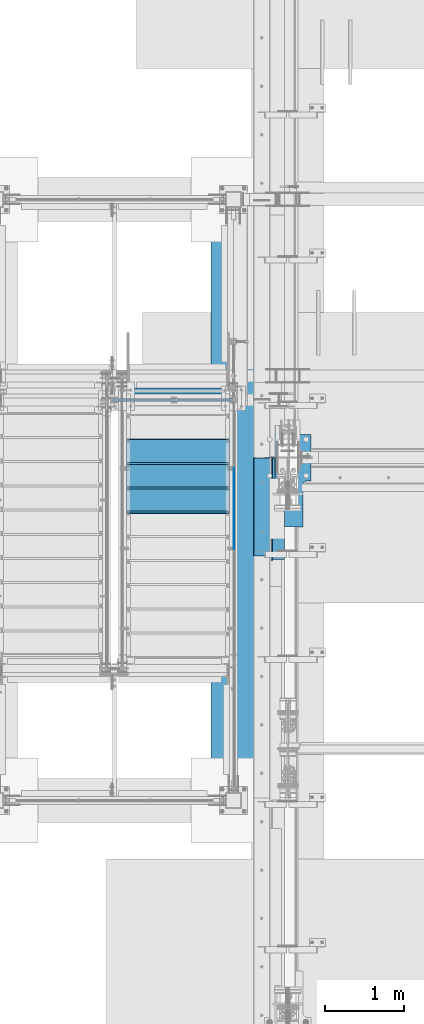
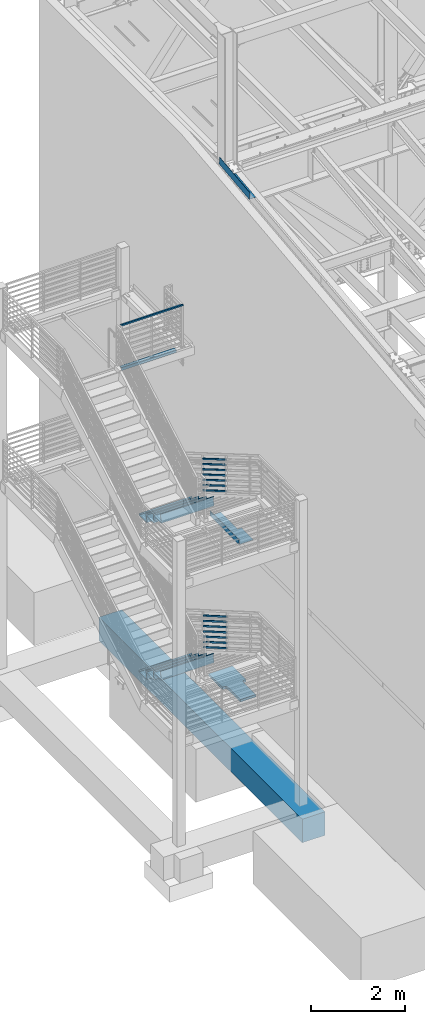
# One storey, part 762 of 1179: 14 members, 12 beams, 10 elements without a shape of their own.
"""IFC2X3 building model written with IfcOpenShell, lengths in millimetres."""

from ifc_helpers import new_model, si_unit, frame, origin_with_axes, place, context, subcontext, project, spatial, faceted_brep, material, type_object, element, aggregate, save


model = new_model("IFC2X3")

# Units and contexts
model_context = context("Model", 3, precision=1e-05, world=origin_with_axes())
body_context = subcontext(model_context, "Body", "Model", "MODEL_VIEW")
ifc_project = project(units=[si_unit("LENGTHUNIT", "METRE", prefix="MILLI"), si_unit("AREAUNIT", "SQUARE_METRE"), si_unit("VOLUMEUNIT", "CUBIC_METRE"), si_unit("MASSUNIT", "GRAM", prefix="KILO"), si_unit("TIMEUNIT", "SECOND"), si_unit("PLANEANGLEUNIT", "RADIAN"), si_unit("SOLIDANGLEUNIT", "STERADIAN"), si_unit("THERMODYNAMICTEMPERATUREUNIT", "DEGREE_CELSIUS"), si_unit("LUMINOUSINTENSITYUNIT", "LUMEN")], contexts=[model_context])

# Site, building, storey
site_placement = place(None, origin_with_axes())
site = spatial("IfcSite", under=ifc_project, at=site_placement, CompositionType="ELEMENT")
building_placement = place(site_placement, origin_with_axes())
building = spatial("IfcBuilding", under=site, at=building_placement, Name="Undefined", CompositionType="ELEMENT")
storey_placement = place(building_placement, origin_with_axes())
storey = spatial("IfcBuildingStorey", under=building, at=storey_placement, Name="Undefined", CompositionType="ELEMENT", Elevation=0.0)

# Assembly, beam
assembly_1_placement = place(storey_placement, origin_with_axes())
assembly_1 = element("IfcElementAssembly", 1, at=assembly_1_placement, inside=storey, Name="GUARDRAIL", AssemblyPlace="NOTDEFINED", PredefinedType="RIGID_FRAME")
ifc_material_1 = material()
beam_type_1 = type_object("IfcBeamType", Name="HSS1-1/2X1-1/2X1/4", PredefinedType="NOTDEFINED")
beam_1_placement = place(assembly_1_placement, frame((-1752.5993037225, 35115.5, 9213.90291797146), z_axis=(3.65500000116299e-05, 0.0, 0.999999999332049), x_axis=(0.999999999332049, 0.0, -3.65500000117319e-05)))
beam_1 = element("IfcBeam", 2, at=beam_1_placement, type_object=beam_type_1, material=ifc_material_1, Name="GUARDRAIL", ObjectType="HSS1-1/2X1-1/2X1/4", context=body_context, shape_type="Brep", body=[
    faceted_brep([(12.6997672797793, 12.6999993299978, -12.6999993300051), (12.6997672797793, -12.6999993299978, -12.6999993300051), (1511.30115616268, -12.6999993299978, -12.6999993299942), (1485.90022919769, 12.6999993299978, -12.699999329996), (-12.7011597941691, -12.6999993299978, 12.6999993300033), (1511.30115618808, -12.6999993299978, 12.699999330016), (-12.7011597941691, 12.6999993299978, 12.6999993300033), (1485.90022922309, 12.6999993299978, 12.6999993300142), (19.0499999999993, 19.0499992349996, -19.0499992350015), (-19.0513918026652, 19.0499992350015, 19.0499992350051), (1479.54999724818, 19.0499992350015, 19.049999235016), (1479.54999721008, 19.0499992350015, -19.0499992349978), (-19.0513918026652, -19.0499992350015, 19.0499992350051), (1517.65138817569, -19.0499992350015, 19.0499992350178), (19.0499999999993, -19.0499992349996, -19.0499992350015), (1517.65138813759, -19.0499992350015, -19.049999234996)], [[[0, 1, 2, 3]], [[1, 4, 5, 2]], [[4, 6, 7, 5]], [[6, 0, 3, 7]], [[8, 9, 10, 11]], [[9, 12, 13, 10]], [[12, 14, 15, 13]], [[14, 8, 11, 15]], [[13, 15, 11, 10], [5, 7, 3, 2]], [[14, 12, 9, 8], [6, 4, 1, 0]]]),
])
aggregate(assembly_1, [beam_1])

assembly_2_placement = place(storey_placement, origin_with_axes())
assembly_2 = element("IfcElementAssembly", 3, at=assembly_2_placement, inside=storey, Name="BEAM", AssemblyPlace="NOTDEFINED", PredefinedType="RIGID_FRAME")
ifc_material_2 = material(Name="STEEL/A36")
beam_type_2 = type_object("IfcBeamType", Name="L3X3X1/4", PredefinedType="NOTDEFINED")
beam_2_placement = place(assembly_2_placement, frame((-1703.3875, 35229.8, 8007.35), z_axis=(0.0, 0.0, -1.0), x_axis=(1.0, 0.0, 0.0)))
beam_2 = element("IfcBeam", 4, at=beam_2_placement, type_object=beam_type_2, material=ifc_material_2, Name="ANGLE", ObjectType="L3X3X1/4", context=body_context, shape_type="Brep", body=[
    faceted_brep([(0.0, 38.0999999999985, -38.0999999999999), (0.0, 38.0999999999985, 38.0999999999999), (1347.78749780986, 38.0999999999985, 38.1000000000004), (1347.78749780986, 38.0999999999985, -38.1000000000004), (0.0, 31.75, 38.1000000000004), (1347.78749780986, 31.75, 38.1000000000004), (0.0, 31.75, -31.75), (1347.78749780986, 31.75, -31.75), (0.0, -38.0999999999985, -31.75), (1347.78749780986, -38.0999999999985, -31.75), (0.0, -38.0999999999985, -38.0999999999999), (1347.78749780986, -38.0999999999985, -38.1000000000004)], [[[0, 1, 2, 3]], [[1, 4, 5, 2]], [[4, 6, 7, 5]], [[6, 8, 9, 7]], [[8, 10, 11, 9]], [[10, 0, 3, 11]], [[5, 7, 9, 11, 3, 2]], [[10, 8, 6, 4, 1, 0]]]),
])
aggregate(assembly_2, [beam_2])

# Assembly, members
assembly_3_placement = place(storey_placement, origin_with_axes())
assembly_3 = element("IfcElementAssembly", 5, at=assembly_3_placement, inside=storey, Name="GUARDRAIL", AssemblyPlace="NOTDEFINED", PredefinedType="RIGID_FRAME")
member_type = type_object("IfcMemberType", PredefinedType="NOTDEFINED")
member_1_placement = place(assembly_3_placement, frame((-247.650000724804, 34260.0809190588, 5742.33078305842), z_axis=(0.0, 0.503871025834968, 0.863778900717086), x_axis=(0.0, -0.863778900717086, 0.503871025834967)))
member_1 = element("IfcMember", 6, at=member_1_placement, type_object=member_type, material=ifc_material_2, Name="PLATE", context=body_context, shape_type="Brep", body=[
    faceted_brep([(-16.7114354625264, 4.76250000000005, -19.0500000000065), (5.51356370517169, 4.76250000000005, 19.0500000000338), (1164.83261782332, 4.76250000000005, 19.0499999989988), (1142.607617805, 4.76250000000005, -19.0500000010361), (5.51356370517169, -4.76250000000005, 19.0500000000338), (1164.83261782332, -4.76250000000005, 19.0499999989988), (-16.7114354625264, -4.76250000000005, -19.0500000000065), (1142.607617805, -4.76250000000005, -19.0500000010361)], [[[0, 1, 2, 3]], [[1, 4, 5, 2]], [[4, 6, 7, 5]], [[6, 0, 3, 7]], [[5, 7, 3, 2]], [[6, 4, 1, 0]]]),
])
member_2_placement = place(assembly_3_placement, frame((-247.650000724804, 34260.0809190354, 5606.14727295361), z_axis=(0.0, 0.503871025834968, 0.863778900717086), x_axis=(0.0, -0.863778900717086, 0.503871025834967)))
member_2 = element("IfcMember", 7, at=member_2_placement, type_object=member_type, material=ifc_material_2, Name="PLATE", context=body_context, shape_type="Brep", body=[
    faceted_brep([(-16.7114354625264, 4.76250000000005, -19.0500000000065), (5.51356370517169, 4.76250000000005, 19.0500000000338), (1164.83261782332, 4.76250000000005, 19.0499999989988), (1142.607617805, 4.76250000000005, -19.0500000010361), (5.51356370517169, -4.76250000000005, 19.0500000000338), (1164.83261782332, -4.76250000000005, 19.0499999989988), (-16.7114354625264, -4.76250000000005, -19.0500000000065), (1142.607617805, -4.76250000000005, -19.0500000010361)], [[[0, 1, 2, 3]], [[1, 4, 5, 2]], [[4, 6, 7, 5]], [[6, 0, 3, 7]], [[5, 7, 3, 2]], [[6, 4, 1, 0]]]),
])
member_3_placement = place(assembly_3_placement, frame((-247.650000724804, 34260.0809190396, 5469.96376335513), z_axis=(0.0, 0.503871025834968, 0.863778900717086), x_axis=(0.0, -0.863778900717086, 0.503871025834967)))
member_3 = element("IfcMember", 8, at=member_3_placement, type_object=member_type, material=ifc_material_2, Name="PLATE", context=body_context, shape_type="Brep", body=[
    faceted_brep([(-16.7114354625264, 4.76250000000005, -19.0500000000065), (5.51356370517169, 4.76250000000005, 19.0500000000338), (1164.83261782332, 4.76250000000005, 19.0499999989988), (1142.607617805, 4.76250000000005, -19.0500000010361), (5.51356370517169, -4.76250000000005, 19.0500000000338), (1164.83261782332, -4.76250000000005, 19.0499999989988), (-16.7114354625264, -4.76250000000005, -19.0500000000065), (1142.607617805, -4.76250000000005, -19.0500000010361)], [[[0, 1, 2, 3]], [[1, 4, 5, 2]], [[4, 6, 7, 5]], [[6, 0, 3, 7]], [[5, 7, 3, 2]], [[6, 4, 1, 0]]]),
])
member_4_placement = place(assembly_3_placement, frame((-247.650000724804, 34260.0809190439, 5333.78025375723), z_axis=(0.0, 0.503871025834968, 0.863778900717086), x_axis=(0.0, -0.863778900717086, 0.503871025834967)))
member_4 = element("IfcMember", 9, at=member_4_placement, type_object=member_type, material=ifc_material_2, Name="PLATE", context=body_context, shape_type="Brep", body=[
    faceted_brep([(-16.7114354625264, 4.76250000000005, -19.0500000000065), (5.51356370517169, 4.76250000000005, 19.0500000000338), (1164.83261782332, 4.76250000000005, 19.0499999989988), (1142.607617805, 4.76250000000005, -19.0500000010361), (5.51356370517169, -4.76250000000005, 19.0500000000338), (1164.83261782332, -4.76250000000005, 19.0499999989988), (-16.7114354625264, -4.76250000000005, -19.0500000000065), (1142.607617805, -4.76250000000005, -19.0500000010361)], [[[0, 1, 2, 3]], [[1, 4, 5, 2]], [[4, 6, 7, 5]], [[6, 0, 3, 7]], [[5, 7, 3, 2]], [[6, 4, 1, 0]]]),
])
member_5_placement = place(assembly_3_placement, frame((-247.650000724804, 34260.0809190481, 5197.59674415903), z_axis=(0.0, 0.503871025834968, 0.863778900717086), x_axis=(0.0, -0.863778900717086, 0.503871025834967)))
member_5 = element("IfcMember", 10, at=member_5_placement, type_object=member_type, material=ifc_material_2, Name="PLATE", context=body_context, shape_type="Brep", body=[
    faceted_brep([(-16.7114354625264, 4.76250000000005, -19.0500000000065), (5.51356370517169, 4.76250000000005, 19.0500000000338), (1164.83261782332, 4.76250000000005, 19.0499999989988), (1142.607617805, 4.76250000000005, -19.0500000010361), (5.51356370517169, -4.76250000000005, 19.0500000000338), (1164.83261782332, -4.76250000000005, 19.0499999989988), (-16.7114354625264, -4.76250000000005, -19.0500000000065), (1142.607617805, -4.76250000000005, -19.0500000010361)], [[[0, 1, 2, 3]], [[1, 4, 5, 2]], [[4, 6, 7, 5]], [[6, 0, 3, 7]], [[5, 7, 3, 2]], [[6, 4, 1, 0]]]),
])
member_6_placement = place(assembly_3_placement, frame((-247.650000724804, 34260.0809190523, 5061.41323456027), z_axis=(0.0, 0.503871025834968, 0.863778900717086), x_axis=(0.0, -0.863778900717086, 0.503871025834967)))
member_6 = element("IfcMember", 11, at=member_6_placement, type_object=member_type, material=ifc_material_2, Name="PLATE", context=body_context, shape_type="Brep", body=[
    faceted_brep([(-16.7114354625264, 4.76250000000005, -19.0500000000065), (5.51356370517169, 4.76250000000005, 19.0500000000338), (1164.83261782332, 4.76250000000005, 19.0499999989988), (1142.607617805, 4.76250000000005, -19.0500000010361), (5.51356370517169, -4.76250000000005, 19.0500000000338), (1164.83261782332, -4.76250000000005, 19.0499999989988), (-16.7114354625264, -4.76250000000005, -19.0500000000065), (1142.607617805, -4.76250000000005, -19.0500000010361)], [[[0, 1, 2, 3]], [[1, 4, 5, 2]], [[4, 6, 7, 5]], [[6, 0, 3, 7]], [[5, 7, 3, 2]], [[6, 4, 1, 0]]]),
])
member_7_placement = place(assembly_3_placement, frame((-247.650000724804, 34260.0809190565, 4925.22972496178), z_axis=(0.0, 0.503871025834968, 0.863778900717086), x_axis=(0.0, -0.863778900717086, 0.503871025834967)))
member_7 = element("IfcMember", 12, at=member_7_placement, type_object=member_type, material=ifc_material_2, Name="PLATE", context=body_context, shape_type="Brep", body=[
    faceted_brep([(-16.7114354625264, 4.76250000000005, -19.0500000000065), (5.51356370517169, 4.76250000000005, 19.0500000000338), (1164.83261782332, 4.76250000000005, 19.0499999989988), (1142.607617805, 4.76250000000005, -19.0500000010361), (5.51356370517169, -4.76250000000005, 19.0500000000338), (1164.83261782332, -4.76250000000005, 19.0499999989988), (-16.7114354625264, -4.76250000000005, -19.0500000000065), (1142.607617805, -4.76250000000005, -19.0500000010361)], [[[0, 1, 2, 3]], [[1, 4, 5, 2]], [[4, 6, 7, 5]], [[6, 0, 3, 7]], [[5, 7, 3, 2]], [[6, 4, 1, 0]]]),
])
aggregate(assembly_3, [member_1, member_2, member_3, member_4, member_5, member_6, member_7])

assembly_4_placement = place(storey_placement, origin_with_axes())
assembly_4 = element("IfcElementAssembly", 13, at=assembly_4_placement, inside=storey, Name="GUARDRAIL", AssemblyPlace="NOTDEFINED", PredefinedType="RIGID_FRAME")
member_8_placement = place(assembly_4_placement, frame((-247.650000724804, 34229.6545045591, 1696.79854461329), z_axis=(0.0, 0.501075923252298, 0.865403327435744), x_axis=(0.0, -0.865403327435743, 0.501075923252299)))
member_8 = element("IfcMember", 14, at=member_8_placement, type_object=member_type, material=ifc_material_2, Name="PLATE", context=body_context, shape_type="Brep", body=[
    faceted_brep([(-16.5570104603576, 4.76250000000005, -19.0500000000102), (5.50317738577724, 4.76250000000005, 19.0499999999902), (1153.84060725657, 4.76250000000005, 19.0499999998246), (1131.78038161306, 4.76250000000005, -19.0500000001994), (5.50317738577724, -4.76250000000005, 19.0499999999902), (1153.84060725657, -4.76250000000005, 19.0499999998246), (-16.5570104603576, -4.76250000000005, -19.0500000000102), (1131.78038161306, -4.76250000000005, -19.0500000001994)], [[[0, 1, 2, 3]], [[1, 4, 5, 2]], [[4, 6, 7, 5]], [[6, 0, 3, 7]], [[5, 7, 3, 2]], [[6, 4, 1, 0]]]),
])
member_9_placement = place(assembly_4_placement, frame((-247.650000724804, 34229.6545040284, 1560.69783019579), z_axis=(0.0, 0.501075923252298, 0.865403327435744), x_axis=(0.0, -0.865403327435743, 0.501075923252299)))
member_9 = element("IfcMember", 15, at=member_9_placement, type_object=member_type, material=ifc_material_2, Name="PLATE", context=body_context, shape_type="Brep", body=[
    faceted_brep([(-16.5570104603576, 4.76250000000005, -19.0500000000102), (5.50317738577724, 4.76250000000005, 19.0499999999902), (1153.84060725657, 4.76250000000005, 19.0499999998246), (1131.78038161306, 4.76250000000005, -19.0500000001994), (5.50317738577724, -4.76250000000005, 19.0499999999902), (1153.84060725657, -4.76250000000005, 19.0499999998246), (-16.5570104603576, -4.76250000000005, -19.0500000000102), (1131.78038161306, -4.76250000000005, -19.0500000001994)], [[[0, 1, 2, 3]], [[1, 4, 5, 2]], [[4, 6, 7, 5]], [[6, 0, 3, 7]], [[5, 7, 3, 2]], [[6, 4, 1, 0]]]),
])
member_10_placement = place(assembly_4_placement, frame((-247.650000724804, 34229.6545218156, 1424.59711548055), z_axis=(0.0, 0.501075923252298, 0.865403327435744), x_axis=(0.0, -0.865403327435743, 0.501075923252299)))
member_10 = element("IfcMember", 16, at=member_10_placement, type_object=member_type, material=ifc_material_2, Name="PLATE", context=body_context, shape_type="Brep", body=[
    faceted_brep([(-16.5570104603576, 4.76250000000005, -19.0500000000102), (5.50317738577724, 4.76250000000005, 19.0499999999902), (1153.84060725657, 4.76250000000005, 19.0499999998246), (1131.78038161306, 4.76250000000005, -19.0500000001994), (5.50317738577724, -4.76250000000005, 19.0499999999902), (1153.84060725657, -4.76250000000005, 19.0499999998246), (-16.5570104603576, -4.76250000000005, -19.0500000000102), (1131.78038161306, -4.76250000000005, -19.0500000001994)], [[[0, 1, 2, 3]], [[1, 4, 5, 2]], [[4, 6, 7, 5]], [[6, 0, 3, 7]], [[5, 7, 3, 2]], [[6, 4, 1, 0]]]),
])
member_11_placement = place(assembly_4_placement, frame((-247.650000724804, 34229.6545389646, 1288.49640076449), z_axis=(0.0, 0.501075923252298, 0.865403327435744), x_axis=(0.0, -0.865403327435743, 0.501075923252299)))
member_11 = element("IfcMember", 17, at=member_11_placement, type_object=member_type, material=ifc_material_2, Name="PLATE", context=body_context, shape_type="Brep", body=[
    faceted_brep([(-16.5570104603576, 4.76250000000005, -19.0500000000102), (5.50317738577724, 4.76250000000005, 19.0499999999902), (1153.84060725657, 4.76250000000005, 19.0499999998246), (1131.78038161306, 4.76250000000005, -19.0500000001994), (5.50317738577724, -4.76250000000005, 19.0499999999902), (1153.84060725657, -4.76250000000005, 19.0499999998246), (-16.5570104603576, -4.76250000000005, -19.0500000000102), (1131.78038161306, -4.76250000000005, -19.0500000001994)], [[[0, 1, 2, 3]], [[1, 4, 5, 2]], [[4, 6, 7, 5]], [[6, 0, 3, 7]], [[5, 7, 3, 2]], [[6, 4, 1, 0]]]),
])
member_12_placement = place(assembly_4_placement, frame((-247.650000724804, 34229.6545554989, 1152.39568605121), z_axis=(0.0, 0.501075923252298, 0.865403327435744), x_axis=(0.0, -0.865403327435743, 0.501075923252299)))
member_12 = element("IfcMember", 18, at=member_12_placement, type_object=member_type, material=ifc_material_2, Name="PLATE", context=body_context, shape_type="Brep", body=[
    faceted_brep([(-16.5570104603576, 4.76250000000005, -19.0500000000102), (5.50317738577724, 4.76250000000005, 19.0499999999902), (1153.84060725657, 4.76250000000005, 19.0499999998246), (1131.78038161306, 4.76250000000005, -19.0500000001994), (5.50317738577724, -4.76250000000005, 19.0499999999902), (1153.84060725657, -4.76250000000005, 19.0499999998246), (-16.5570104603576, -4.76250000000005, -19.0500000000102), (1131.78038161306, -4.76250000000005, -19.0500000001994)], [[[0, 1, 2, 3]], [[1, 4, 5, 2]], [[4, 6, 7, 5]], [[6, 0, 3, 7]], [[5, 7, 3, 2]], [[6, 4, 1, 0]]]),
])
member_13_placement = place(assembly_4_placement, frame((-247.650000724804, 34229.6545714411, 1016.29497138553), z_axis=(0.0, 0.501075923252298, 0.865403327435744), x_axis=(0.0, -0.865403327435743, 0.501075923252299)))
member_13 = element("IfcMember", 19, at=member_13_placement, type_object=member_type, material=ifc_material_2, Name="PLATE", context=body_context, shape_type="Brep", body=[
    faceted_brep([(-16.5570104603576, 4.76250000000005, -19.0500000000102), (5.50317738577724, 4.76250000000005, 19.0499999999902), (1153.84060725657, 4.76250000000005, 19.0499999998246), (1131.78038161306, 4.76250000000005, -19.0500000001994), (5.50317738577724, -4.76250000000005, 19.0499999999902), (1153.84060725657, -4.76250000000005, 19.0499999998246), (-16.5570104603576, -4.76250000000005, -19.0500000000102), (1131.78038161306, -4.76250000000005, -19.0500000001994)], [[[0, 1, 2, 3]], [[1, 4, 5, 2]], [[4, 6, 7, 5]], [[6, 0, 3, 7]], [[5, 7, 3, 2]], [[6, 4, 1, 0]]]),
])
member_14_placement = place(assembly_4_placement, frame((-247.650000724804, 34229.6545868112, 880.194256721812), z_axis=(0.0, 0.501075923252298, 0.865403327435744), x_axis=(0.0, -0.865403327435743, 0.501075923252299)))
member_14 = element("IfcMember", 20, at=member_14_placement, type_object=member_type, material=ifc_material_2, Name="PLATE", context=body_context, shape_type="Brep", body=[
    faceted_brep([(-16.5570104603576, 4.76250000000005, -19.0500000000102), (5.50317738577724, 4.76250000000005, 19.0499999999902), (1153.84060725657, 4.76250000000005, 19.0499999998246), (1131.78038161306, 4.76250000000005, -19.0500000001994), (5.50317738577724, -4.76250000000005, 19.0499999999902), (1153.84060725657, -4.76250000000005, 19.0499999998246), (-16.5570104603576, -4.76250000000005, -19.0500000000102), (1131.78038161306, -4.76250000000005, -19.0500000001994)], [[[0, 1, 2, 3]], [[1, 4, 5, 2]], [[4, 6, 7, 5]], [[6, 0, 3, 7]], [[5, 7, 3, 2]], [[6, 4, 1, 0]]]),
])
aggregate(assembly_4, [member_8, member_9, member_10, member_11, member_12, member_13, member_14])

# Assembly, beams
assembly_5_placement = place(storey_placement, origin_with_axes())
assembly_5 = element("IfcElementAssembly", 21, at=assembly_5_placement, inside=storey, Name="STRINGER", AssemblyPlace="NOTDEFINED", PredefinedType="RIGID_FRAME")
beam_type_3 = type_object("IfcBeamType", PredefinedType="NOTDEFINED")
beam_3_placement = place(assembly_5_placement, frame((-952.499999979556, 33693.1009224081, 1057.29905401664), z_axis=(-1.0, 0.0, 0.0), x_axis=(0.0, 1.0, 0.0)))
beam_3 = element("IfcBeam", 22, at=beam_3_placement, type_object=beam_type_3, material=ifc_material_2, Name="TREAD", context=body_context, shape_type="Brep", body=[
    faceted_brep([(-5.47515810467303e-10, -1.58750000000146, -647.7), (-5.47515810467303e-10, -1.58750000000146, 647.7), (5.49334799870849e-10, 1.58749999999418, 647.7), (5.49334799870849e-10, 1.58749999999418, -647.7), (21.7353257776667, 1.58750000000009, 647.7), (21.7353257776667, 1.58750000000009, -647.7), (25.4000000001688, -1.58750000000009, -647.7), (25.4000000001688, -1.58750000000009, 647.7), (-10.9760191413625, 228.869394137143, 647.7), (-10.9760191413625, 228.869394137143, -647.7), (-7.31134491886041, 225.694394137142, -647.7), (-7.31134491886041, 225.694394137142, 647.7), (319.224134592409, 228.869394137143, 647.7), (319.224134592409, 228.869394137143, -647.7), (316.473378484785, 225.694394137142, -647.7), (316.473378484785, 225.694394137142, 647.7), (325.043579912828, 188.435270791671, 647.7), (325.043579912828, 188.435270791671, -647.7), (321.900961419207, 187.982972213801, 647.7), (321.900961419207, 187.982972213801, -647.7)], [[[0, 1, 2, 3]], [[3, 2, 4, 5]], [[1, 0, 6, 7]], [[5, 4, 8, 9]], [[7, 6, 10, 11]], [[9, 8, 12, 13]], [[11, 10, 14, 15]], [[13, 12, 16, 17]], [[12, 8, 4, 2, 1, 7, 11, 15, 18, 16]], [[15, 14, 19, 18]], [[14, 10, 6, 0, 3, 5, 9, 13, 17, 19]], [[18, 19, 17, 16]]]),
])
beam_4_placement = place(assembly_5_placement, frame((-952.499999979516, 33997.9010761421, 880.817159879493), z_axis=(-1.0, 0.0, 0.0), x_axis=(0.0, 1.0, 0.0)))
beam_4 = element("IfcBeam", 23, at=beam_4_placement, type_object=beam_type_3, material=ifc_material_2, Name="TREAD", context=body_context, shape_type="Brep", body=[
    faceted_brep([(-5.47515810467303e-10, -1.58750000000146, -647.7), (-5.47515810467303e-10, -1.58750000000146, 647.7), (5.49334799870849e-10, 1.58749999999418, 647.7), (5.49334799870849e-10, 1.58749999999418, -647.7), (21.7353257776667, 1.58750000000009, 647.7), (21.7353257776667, 1.58750000000009, -647.7), (25.4000000001688, -1.58750000000009, -647.7), (25.4000000001688, -1.58750000000009, 647.7), (-10.9760191413625, 228.869394137143, 647.7), (-10.9760191413625, 228.869394137143, -647.7), (-7.31134491886041, 225.694394137142, -647.7), (-7.31134491886041, 225.694394137142, 647.7), (319.224134592409, 228.869394137143, 647.7), (319.224134592409, 228.869394137143, -647.7), (316.473378484785, 225.694394137142, -647.7), (316.473378484785, 225.694394137142, 647.7), (325.043579912828, 188.435270791671, 647.7), (325.043579912828, 188.435270791671, -647.7), (321.900961419207, 187.982972213801, 647.7), (321.900961419207, 187.982972213801, -647.7)], [[[0, 1, 2, 3]], [[3, 2, 4, 5]], [[1, 0, 6, 7]], [[5, 4, 8, 9]], [[7, 6, 10, 11]], [[9, 8, 12, 13]], [[11, 10, 14, 15]], [[13, 12, 16, 17]], [[12, 8, 4, 2, 1, 7, 11, 15, 18, 16]], [[15, 14, 19, 18]], [[14, 10, 6, 0, 3, 5, 9, 13, 17, 19]], [[18, 19, 17, 16]]]),
])
beam_5_placement = place(assembly_5_placement, frame((-952.499999979476, 34302.7012298762, 704.335265742351), z_axis=(-1.0, 0.0, 0.0), x_axis=(0.0, 1.0, 0.0)))
beam_5 = element("IfcBeam", 24, at=beam_5_placement, type_object=beam_type_3, material=ifc_material_2, Name="TREAD", context=body_context, shape_type="Brep", body=[
    faceted_brep([(-5.47515810467303e-10, -1.58750000000146, -647.7), (-5.47515810467303e-10, -1.58750000000146, 647.7), (5.49334799870849e-10, 1.58749999999418, 647.7), (5.49334799870849e-10, 1.58749999999418, -647.7), (21.7353257776667, 1.58750000000009, 647.7), (21.7353257776667, 1.58750000000009, -647.7), (25.4000000001688, -1.58750000000009, -647.7), (25.4000000001688, -1.58750000000009, 647.7), (-10.9760191413625, 228.869394137143, 647.7), (-10.9760191413625, 228.869394137143, -647.7), (-7.31134491886041, 225.694394137142, -647.7), (-7.31134491886041, 225.694394137142, 647.7), (319.224134592409, 228.869394137143, 647.7), (319.224134592409, 228.869394137143, -647.7), (316.473378484785, 225.694394137142, -647.7), (316.473378484785, 225.694394137142, 647.7), (325.043579912828, 188.435270791671, 647.7), (325.043579912828, 188.435270791671, -647.7), (321.900961419207, 187.982972213801, 647.7), (321.900961419207, 187.982972213801, -647.7)], [[[0, 1, 2, 3]], [[3, 2, 4, 5]], [[1, 0, 6, 7]], [[5, 4, 8, 9]], [[7, 6, 10, 11]], [[9, 8, 12, 13]], [[11, 10, 14, 15]], [[13, 12, 16, 17]], [[12, 8, 4, 2, 1, 7, 11, 15, 18, 16]], [[15, 14, 19, 18]], [[14, 10, 6, 0, 3, 5, 9, 13, 17, 19]], [[18, 19, 17, 16]]]),
])
aggregate(assembly_5, [beam_3, beam_4, beam_5])

# Assembly, beam
assembly_6_placement = place(storey_placement, origin_with_axes())
assembly_6 = element("IfcElementAssembly", 25, at=assembly_6_placement, inside=storey, Name="BEAM", AssemblyPlace="NOTDEFINED", PredefinedType="RIGID_FRAME")
beam_type_4 = type_object("IfcBeamType", PredefinedType="NOTDEFINED")
beam_6_placement = place(assembly_6_placement, frame((388.937000011028, 33750.823930991, 13063.8736849896), z_axis=(0.0, -0.993676146336441, -0.112284087038017), x_axis=(-1.0, 0.0, 0.0)))
beam_6 = element("IfcBeam", 26, at=beam_6_placement, type_object=beam_type_4, material=ifc_material_2, Name="BENT_PLATE", context=body_context, shape_type="Brep", body=[
    faceted_brep([(120.649507240023, -3.17499999981737, -222.223428618498), (120.649527521575, 3.17486569206812, -222.223431928272), (120.649992447262, 3.17500000052132, -643.731500001944), (120.649972166385, -3.17499999947358, -643.731500001952), (5.14432940690313e-11, -3.17499999981919, -222.223406928701), (5.14432940690313e-11, 3.17500000017753, -222.223410238686), (160.337000001678, 3.17499999947358, 643.731500001995), (-1.48986600834178e-10, 3.17499999947358, 643.731500001959), (-1.48986600834178e-10, -3.17500000052314, 643.731500001952), (153.987000001678, -3.17500000052314, 643.731500001988), (153.987000001805, -187.324999998971, 643.731500001959), (160.337000001805, -187.324999998971, 643.731500001959), (160.337000002226, 3.17500000052314, -643.731500001937), (160.337000002098, -187.324999998182, -643.731500001981), (153.987000002098, -187.324999998182, -643.731500001981), (153.987000002226, -3.1749999994754, -643.731500001944)], [[[0, 1, 2, 3]], [[4, 5, 1, 0]], [[6, 7, 8, 9, 10, 11]], [[12, 6, 11, 13]], [[10, 14, 13, 11]], [[9, 15, 14, 10]], [[12, 13, 14, 15, 3, 2]], [[7, 6, 12, 2, 1, 5]], [[8, 7, 5, 4]], [[15, 9, 8, 4, 0, 3]]]),
])
aggregate(assembly_6, [beam_6])

# Assembly, beams
assembly_7_placement = place(storey_placement, origin_with_axes())
assembly_7 = element("IfcElementAssembly", 27, at=assembly_7_placement, inside=storey, Name="STRINGER", AssemblyPlace="NOTDEFINED", PredefinedType="RIGID_FRAME")
beam_type_5 = type_object("IfcBeamType", PredefinedType="NOTDEFINED")
beam_7_placement = place(assembly_7_placement, frame((-952.499999991618, 33693.0999996413, 5122.86249934089), z_axis=(-1.0, 0.0, 0.0), x_axis=(0.0, 1.0, 0.0)))
beam_7 = element("IfcBeam", 28, at=beam_7_placement, type_object=beam_type_5, material=ifc_material_2, Name="TREAD", context=body_context, shape_type="Brep", body=[
    faceted_brep([(-5.47515810467303e-10, -1.58750000000146, -647.7), (-5.47515810467303e-10, -1.58750000000146, 647.7), (5.49334799870849e-10, 1.58749999999418, 647.7), (5.49334799870849e-10, 1.58749999999418, -647.7), (21.7391942417962, 1.58749999999964, 647.7), (21.7391942417962, 1.58749999999964, -647.7), (25.4000000001688, -1.58750000000009, -647.7), (25.4000000001688, -1.58750000000009, 647.7), (-10.9179486153444, 230.1875, 647.7), (-10.9179486153444, 230.1875, -647.7), (-7.25714285782306, 227.012500000001, -647.7), (-7.25714285782306, 227.012500000001, 647.7), (319.2820511338, 230.1875, 647.7), (319.2820511338, 230.1875, -647.7), (316.528388233419, 227.012500000001, -647.7), (316.528388233419, 227.012500000001, 647.7), (325.059631548502, 189.744437097058, 647.7), (325.059631548502, 189.744437097058, -647.7), (321.916541906132, 189.295424291005, 647.7), (321.916541906132, 189.295424291005, -647.7)], [[[0, 1, 2, 3]], [[3, 2, 4, 5]], [[1, 0, 6, 7]], [[5, 4, 8, 9]], [[7, 6, 10, 11]], [[9, 8, 12, 13]], [[11, 10, 14, 15]], [[13, 12, 16, 17]], [[12, 8, 4, 2, 1, 7, 11, 15, 18, 16]], [[15, 14, 19, 18]], [[14, 10, 6, 0, 3, 5, 9, 13, 17, 19]], [[18, 19, 17, 16]]]),
])
beam_8_placement = place(assembly_7_placement, frame((-952.499999996295, 33997.8999995773, 4945.0624992306), z_axis=(-1.0, 0.0, 0.0), x_axis=(0.0, 1.0, 0.0)))
beam_8 = element("IfcBeam", 29, at=beam_8_placement, type_object=beam_type_5, material=ifc_material_2, Name="TREAD", context=body_context, shape_type="Brep", body=[
    faceted_brep([(-5.47515810467303e-10, -1.58750000000146, -647.7), (-5.47515810467303e-10, -1.58750000000146, 647.7), (5.49334799870849e-10, 1.58749999999418, 647.7), (5.49334799870849e-10, 1.58749999999418, -647.7), (21.7391942417962, 1.58749999999964, 647.7), (21.7391942417962, 1.58749999999964, -647.7), (25.4000000001688, -1.58750000000009, -647.7), (25.4000000001688, -1.58750000000009, 647.7), (-10.9179486153444, 230.1875, 647.7), (-10.9179486153444, 230.1875, -647.7), (-7.25714285782306, 227.012500000001, -647.7), (-7.25714285782306, 227.012500000001, 647.7), (319.2820511338, 230.1875, 647.7), (319.2820511338, 230.1875, -647.7), (316.528388233419, 227.012500000001, -647.7), (316.528388233419, 227.012500000001, 647.7), (325.059631548502, 189.744437097058, 647.7), (325.059631548502, 189.744437097058, -647.7), (321.916541906132, 189.295424291005, 647.7), (321.916541906132, 189.295424291005, -647.7)], [[[0, 1, 2, 3]], [[3, 2, 4, 5]], [[1, 0, 6, 7]], [[5, 4, 8, 9]], [[7, 6, 10, 11]], [[9, 8, 12, 13]], [[11, 10, 14, 15]], [[13, 12, 16, 17]], [[12, 8, 4, 2, 1, 7, 11, 15, 18, 16]], [[15, 14, 19, 18]], [[14, 10, 6, 0, 3, 5, 9, 13, 17, 19]], [[18, 19, 17, 16]]]),
])
beam_9_placement = place(assembly_7_placement, frame((-952.500000000973, 34302.6999995133, 4767.26249912149), z_axis=(-1.0, 0.0, 0.0), x_axis=(0.0, 1.0, 0.0)))
beam_9 = element("IfcBeam", 30, at=beam_9_placement, type_object=beam_type_5, material=ifc_material_2, Name="TREAD", context=body_context, shape_type="Brep", body=[
    faceted_brep([(-5.47515810467303e-10, -1.58750000000146, -647.7), (-5.47515810467303e-10, -1.58750000000146, 647.7), (5.49334799870849e-10, 1.58749999999418, 647.7), (5.49334799870849e-10, 1.58749999999418, -647.7), (21.7391942417962, 1.58749999999964, 647.7), (21.7391942417962, 1.58749999999964, -647.7), (25.4000000001688, -1.58750000000009, -647.7), (25.4000000001688, -1.58750000000009, 647.7), (-10.9179486153444, 230.1875, 647.7), (-10.9179486153444, 230.1875, -647.7), (-7.25714285782306, 227.012500000001, -647.7), (-7.25714285782306, 227.012500000001, 647.7), (319.2820511338, 230.1875, 647.7), (319.2820511338, 230.1875, -647.7), (316.528388233419, 227.012500000001, -647.7), (316.528388233419, 227.012500000001, 647.7), (325.059631548502, 189.744437097058, 647.7), (325.059631548502, 189.744437097058, -647.7), (321.916541906132, 189.295424291005, 647.7), (321.916541906132, 189.295424291005, -647.7)], [[[0, 1, 2, 3]], [[3, 2, 4, 5]], [[1, 0, 6, 7]], [[5, 4, 8, 9]], [[7, 6, 10, 11]], [[9, 8, 12, 13]], [[11, 10, 14, 15]], [[13, 12, 16, 17]], [[12, 8, 4, 2, 1, 7, 11, 15, 18, 16]], [[15, 14, 19, 18]], [[14, 10, 6, 0, 3, 5, 9, 13, 17, 19]], [[18, 19, 17, 16]]]),
])
aggregate(assembly_7, [beam_7, beam_8, beam_9])

# Assembly, beam
assembly_8_placement = place(storey_placement, origin_with_axes())
assembly_8 = element("IfcElementAssembly", 31, at=assembly_8_placement, inside=storey, Name="BEAM", AssemblyPlace="NOTDEFINED", PredefinedType="RIGID_FRAME")
beam_type_6 = type_object("IfcBeamType", PredefinedType="NOTDEFINED")
beam_10_placement = place(assembly_8_placement, frame((352.424987792969, 33769.3005, 4105.275), z_axis=(0.0, -1.0, 0.0), x_axis=(-1.0, 0.0, 0.0)))
beam_10 = element("IfcBeam", 32, at=beam_10_placement, type_object=beam_type_6, material=ifc_material_2, Name="BENT_PLATE", context=body_context, shape_type="Brep", body=[
    faceted_brep([(88.8999862670898, -3.17500000000018, 103.188000488277), (88.8999862670898, 3.17500000000018, 103.188000488277), (88.8999862670898, 3.17500000000018, -619.125), (88.8999862670898, -3.17500000000018, -619.125), (0.0, -3.17500000000018, 103.188000488277), (0.0, 3.17500000000018, 103.188000488277), (352.424987792969, 3.17499999999927, 619.125), (0.0, 3.17500000000018, 619.125), (0.0, -3.17500000000018, 619.125), (346.074987792969, -3.17500000000109, 619.125), (346.074987792969, -130.175006103515, 619.125), (352.424987792969, -130.175006103515, 619.125), (352.424987792969, 3.17499999999927, -619.125), (352.424987792969, -130.175006103515, -619.125), (346.074987792969, -130.175006103515, -619.125), (346.074987792969, -3.17500000000109, -619.125)], [[[0, 1, 2, 3]], [[4, 5, 1, 0]], [[6, 7, 8, 9, 10, 11]], [[12, 6, 11, 13]], [[10, 14, 13, 11]], [[9, 15, 14, 10]], [[12, 13, 14, 15, 3, 2]], [[7, 6, 12, 2, 1, 5]], [[8, 7, 5, 4]], [[15, 9, 8, 4, 0, 3]]]),
])
aggregate(assembly_8, [beam_10])

assembly_9_placement = place(storey_placement, origin_with_axes())
assembly_9 = element("IfcElementAssembly", 33, at=assembly_9_placement, inside=storey, Name="GRADE_BEAM", AssemblyPlace="NOTDEFINED", PredefinedType="REINFORCEMENT_UNIT")
ifc_material_3 = material(Name="CONCRETE/5000")
beam_type_7 = type_object("IfcBeamType", PredefinedType="NOTDEFINED")
beam_11_placement = place(assembly_9_placement, frame((-254.0, 29540.2, -939.8), z_axis=(0.0, 0.0, 1.0), x_axis=(0.0, 1.0, 0.0)))
beam_11 = element("IfcBeam", 34, at=beam_11_placement, type_object=beam_type_7, material=ifc_material_3, Name="GRADE_BEAM", context=body_context, shape_type="Brep", body=[
    faceted_brep([(0.0, 279.4, -304.8), (0.0, 279.4, 304.8), (8636.0, 279.4, 304.8), (8636.0, 279.4, -304.8), (0.0, -279.4, 304.8), (8636.0, -279.4, 304.8), (0.0, -279.4, -304.8), (8636.0, -279.4, -304.8)], [[[0, 1, 2, 3]], [[1, 4, 5, 2]], [[4, 6, 7, 5]], [[6, 0, 3, 7]], [[5, 7, 3, 2]], [[6, 4, 1, 0]]]),
])
aggregate(assembly_9, [beam_11])

assembly_10_placement = place(storey_placement, origin_with_axes())
assembly_10 = element("IfcElementAssembly", 35, at=assembly_10_placement, inside=storey, Name="COLUMN", AssemblyPlace="NOTDEFINED", PredefinedType="RIGID_FRAME")
ifc_material_4 = material(Name="STEEL/A572-GR.50")
beam_type_8 = type_object("IfcBeamType", PredefinedType="NOTDEFINED")
beam_12_placement = place(assembly_10_placement, frame((431.799999999996, 34683.69949646, -247.65), z_axis=(1.0, 0.0, 0.0), x_axis=(0.0, -1.0, 0.0)))
beam_12 = element("IfcBeam", 36, at=beam_12_placement, type_object=beam_type_8, material=ifc_material_4, context=body_context, shape_type="Brep", body=[
    faceted_brep([(584.199496459958, -31.75, 292.1), (584.199496459958, -31.75, 241.30000076336), (584.199496459958, 31.75, 241.30000076336), (584.199496459958, 31.75, 292.1), (588.066416150308, -31.75, 221.859682691178), (588.066416150308, 31.75, 221.859682691178), (599.078471752222, -31.75, 205.378976818563), (599.078471752222, 31.75, 205.378976818563), (615.559177624837, -31.75, 194.366921216651), (615.559177624837, 31.75, 194.366921216651), (634.999495697019, -31.75, 190.500001526299), (634.999495697019, 31.75, 190.500001526299), (1168.39847106933, -31.75, 190.500001526299), (1168.39848937988, 31.75, 190.500001526299), (0.0, -31.75, -292.1), (0.0, -31.75, 292.1), (0.0, 31.75, 292.1), (0.0, 31.75, -292.1), (584.199496459958, 31.75, -292.1), (584.199496459958, -31.75, -292.1), (584.199496459958, 31.75, -241.30000076336), (584.199496459958, -31.75, -241.30000076336), (588.066416150308, 31.75, -221.859682691178), (588.066416150308, -31.75, -221.859682691178), (599.078471752222, 31.75, -205.378976818563), (599.078471752222, -31.75, -205.378976818563), (615.559177624837, 31.75, -194.366921216651), (615.559177624837, -31.75, -194.366921216651), (634.999495697019, 31.75, -190.500001526299), (634.999495697019, -31.75, -190.500001526299), (1168.39847106933, -31.75, -190.500001526299), (1168.39848937988, 31.75, -190.500001526299)], [[[0, 1, 2, 3]], [[4, 5, 2, 1]], [[6, 7, 5, 4]], [[8, 9, 7, 6]], [[10, 11, 9, 8]], [[12, 13, 11, 10]], [[14, 15, 16, 17]], [[14, 17, 18, 19]], [[19, 18, 20, 21]], [[21, 20, 22, 23]], [[23, 22, 24, 25]], [[25, 24, 26, 27]], [[27, 26, 28, 29]], [[30, 29, 28, 31]], [[8, 6, 4, 1, 0, 15, 14, 19, 21, 23, 25, 27, 29, 30, 12, 10]], [[16, 15, 0, 3]], [[31, 28, 26, 24, 22, 20, 18, 17, 16, 3, 2, 5, 7, 9, 11, 13]], [[30, 31, 13, 12]]]),
])
aggregate(assembly_10, [beam_12])

save(model, "model.ifc")
